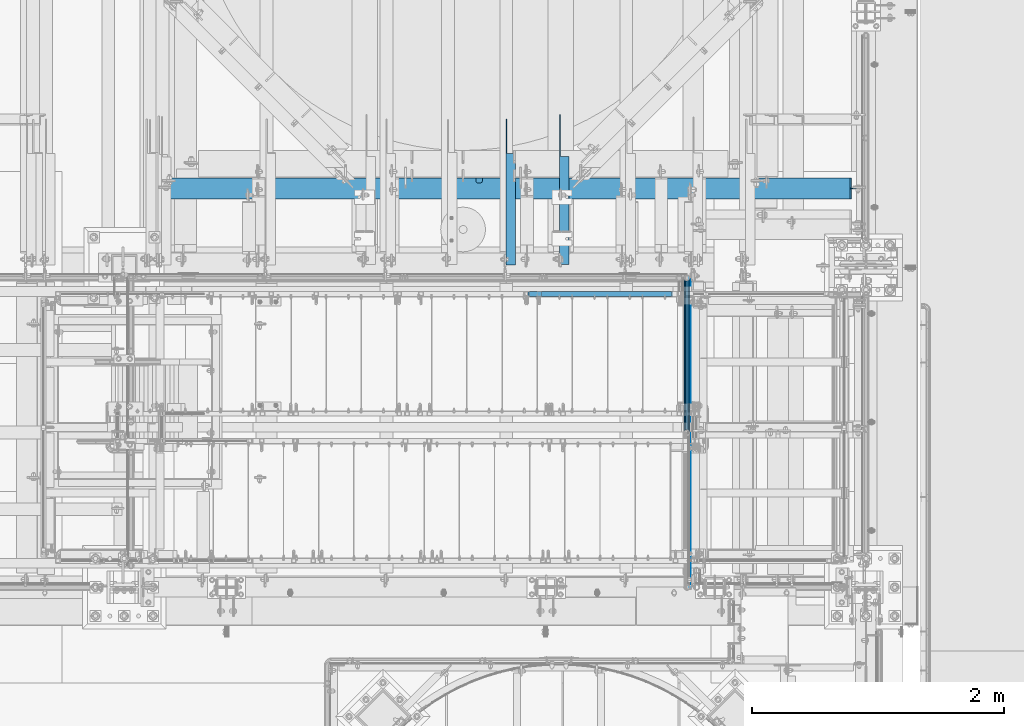
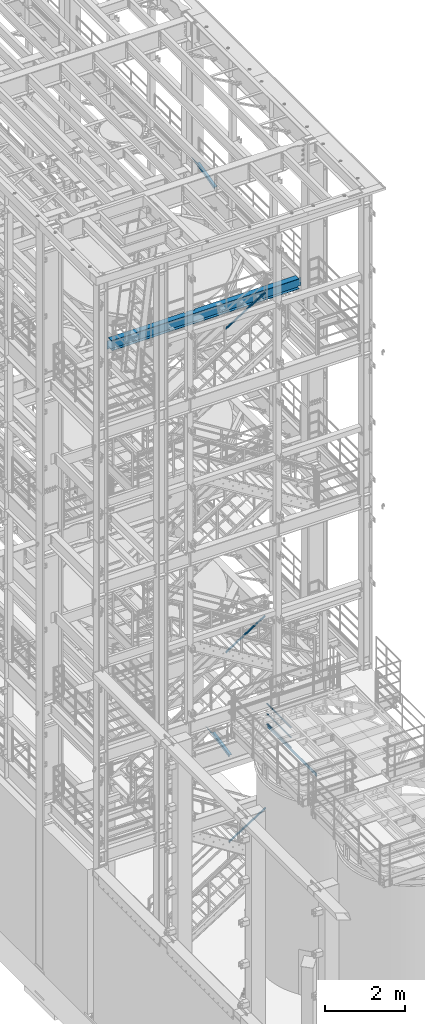
# One storey, part 983 of 1876: 7 beams, 3 members, 7 elements without a shape of their own.
"""IFC2X3 building model written with IfcOpenShell, lengths in millimetres."""

from ifc_helpers import new_model, si_unit, frame, origin_with_axes, place, context, subcontext, project, spatial, faceted_brep, material, type_object, element, aggregate, save


model = new_model("IFC2X3")

# Units and contexts
model_context = context("Model", 3, precision=1e-05, world=origin_with_axes())
body_context = subcontext(model_context, "Body", "Model", "MODEL_VIEW")
ifc_project = project(units=[si_unit("LENGTHUNIT", "METRE", prefix="MILLI"), si_unit("AREAUNIT", "SQUARE_METRE"), si_unit("VOLUMEUNIT", "CUBIC_METRE"), si_unit("MASSUNIT", "GRAM", prefix="KILO"), si_unit("TIMEUNIT", "SECOND"), si_unit("PLANEANGLEUNIT", "RADIAN"), si_unit("SOLIDANGLEUNIT", "STERADIAN"), si_unit("THERMODYNAMICTEMPERATUREUNIT", "DEGREE_CELSIUS"), si_unit("LUMINOUSINTENSITYUNIT", "LUMEN")], contexts=[model_context])

# Site, building, storey
site_placement = place(None, origin_with_axes())
site = spatial("IfcSite", under=ifc_project, at=site_placement, CompositionType="ELEMENT")
building_placement = place(site_placement, origin_with_axes())
building = spatial("IfcBuilding", under=site, at=building_placement, Name="Undefined", CompositionType="ELEMENT")
storey_placement = place(building_placement, origin_with_axes())
storey = spatial("IfcBuildingStorey", under=building, at=storey_placement, Name="Undefined", CompositionType="ELEMENT", Elevation=0.0)

# Assembly, beams
assembly_1_placement = place(storey_placement, origin_with_axes())
assembly_1 = element("IfcElementAssembly", 1, at=assembly_1_placement, inside=storey, Name="RAIL", AssemblyPlace="NOTDEFINED", PredefinedType="RIGID_FRAME")
ifc_material_1 = material()
beam_type_1 = type_object("IfcBeamType", Name="PIPE1-1/2SCH40", PredefinedType="NOTDEFINED")
beam_1_placement = place(assembly_1_placement, frame((6197.59999999999, -4654.55000114548, 5292.725), z_axis=(0.0, 0.0, 1.0), x_axis=(0.0, -1.0, 0.0)))
beam_1 = element("IfcBeam", 2, at=beam_1_placement, type_object=beam_type_1, material=ifc_material_1, Name="RAIL", ObjectType="PIPE1-1/2SCH40", context=body_context, shape_type="Brep", body=[
    faceted_brep([(1207.82780681642, -12.0649999999996, 20.8971929933186), (1207.82780681642, -12.0649999999432, 15.8661214312369), (1207.33437837857, -10.2235000000001, 17.7076214311801), (1204.59499980973, 2.72848410531878e-12, 20.4470000000001), (1204.59499980973, 2.72848410531878e-12, 24.1300000000001), (1207.33437837854, 10.2235000000001, 17.7076214311801), (1207.82780681642, 12.065000000056, 15.8661214311242), (1207.82780681642, 12.0649999999996, 20.8971929933186), (1228.72499980973, 24.1300000000001, 0.0), (1216.65999980973, 20.8971929933186, 12.0649999999996), (1216.65999980973, 20.8971929933186, -12.0649999999996), (1213.47042824754, 17.7076214311801, 10.2235000000001), (1216.20980681636, 20.4470000000001, 0.0), (1213.47042824754, 17.7076214311801, -10.2235000000001), (1207.82780681642, 12.065000000056, -15.8661214311242), (1207.82780681642, 12.0649999999996, -20.8971929933186), (1207.33437837854, 10.2235000000001, -17.7076214311801), (1204.59499980973, 0.0, -20.4470000000001), (1204.59499980973, 0.0, -24.1300000000001), (1207.82780681642, -12.0649999999432, -15.8661214312369), (1207.82780681642, -12.0649999999996, -20.8971929933186), (1207.33437837857, -10.2235000000001, -17.7076214311801), (1228.72499980973, -24.1299999999437, 0.0), (1216.65999980973, -20.8971929933186, -12.0649999999996), (1216.65999980973, -20.8971929933186, 12.0649999999996), (1213.47042824765, -17.7076214311801, -10.2235000000001), (1216.20980681647, -20.4470000000001, 0.0), (1213.47042824765, -17.7076214311801, 10.2235000000001), (12.0650000000064, -20.8971929933177, -12.0649999999987), (20.8971929933249, -12.0650000000005, -20.8971929933177), (0.0, 24.1299999999992, 0.0), (12.0650000000064, 20.8971929933177, -12.0649999999987), (12.0650000000064, 20.8971929933177, 12.0649999999987), (20.8971929933249, 12.0650000000005, 20.8971929933177), (24.1300000000064, 0.0, 24.130000000001), (20.8971929933249, 12.0650000000005, -20.8971929933177), (24.1300000000063, 0.0, -24.130000000001), (24.1300000000063, 0.0, -20.4470000000001), (20.8971929933249, -12.0650000000005, -15.8661214311796), (21.3906214311868, -10.2235000000001, -17.7076214311819), (21.3906214311868, 10.2235000000001, -17.7076214311819), (20.8971929933249, 12.0650000000005, -15.8661214311796), (15.2545715621445, 17.7076214311801, -10.2235000000001), (12.5151929933249, 20.4470000000001, 0.0), (15.2545715621445, 17.7076214311801, 10.2235000000001), (20.8971929933249, 12.0650000000005, 15.8661214311796), (21.3906214311868, 10.2235000000001, 17.7076214311819), (24.1300000000064, 0.0, 20.4470000000001), (21.3906214311868, -10.2235000000001, 17.7076214311819), (20.8971929933249, -12.0650000000005, 15.8661214311796), (20.8971929933249, -12.0650000000005, 20.8971929933177), (12.0650000000064, -20.8971929933177, 12.0649999999987), (0.0, -24.1299999999992, 0.0), (15.2545715621445, -17.7076214311801, 10.2235000000001), (12.5151929933249, -20.4470000000001, 0.0), (15.2545715621445, -17.7076214311801, -10.2235000000001)], [[[0, 1, 2, 3, 4]], [[4, 3, 5, 6, 7]], [[8, 9, 10]], [[7, 6, 11, 12, 13, 14, 15, 10, 9]], [[16, 17, 18, 15, 14]], [[19, 20, 18, 17, 21]], [[22, 23, 24]], [[24, 23, 20, 19, 25, 26, 27, 1, 0]], [[28, 29, 20, 23]], [[30, 31, 32]], [[33, 34, 4, 7]], [[32, 33, 7, 9]], [[30, 32, 9, 8]], [[31, 30, 8, 10]], [[35, 31, 10, 15]], [[36, 35, 15, 18]], [[29, 36, 18, 20]], [[37, 36, 29, 38, 39]], [[40, 41, 35, 36, 37]], [[32, 31, 35, 41, 42, 43, 44, 45, 33]], [[33, 45, 46, 47, 34]], [[34, 47, 48, 49, 50]], [[34, 50, 0, 4]], [[50, 51, 24, 0]], [[51, 52, 22, 24]], [[52, 28, 23, 22]], [[51, 28, 52]], [[50, 49, 53, 54, 55, 38, 29, 28, 51]], [[55, 54, 26, 25]], [[21, 39, 38, 55, 25, 19]], [[37, 39, 21, 17]], [[40, 37, 17, 16]], [[42, 41, 40, 16, 14, 13]], [[43, 42, 13, 12]], [[44, 43, 12, 11]], [[5, 46, 45, 44, 11, 6]], [[47, 46, 5, 3]], [[48, 47, 3, 2]], [[53, 49, 48, 2, 1, 27]], [[54, 53, 27, 26]]]),
])
beam_2_placement = place(assembly_1_placement, frame((6197.60000000216, -5883.27500095527, 5597.525), z_axis=(0.0, 0.0, -1.0), x_axis=(0.0, 1.0, 0.0)))
beam_2 = element("IfcBeam", 3, at=beam_2_placement, type_object=beam_type_1, material=ifc_material_1, Name="RAIL", ObjectType="PIPE1-1/2SCH40", context=body_context, shape_type="Brep", body=[
    faceted_brep([(0.0, 24.1299999999992, 0.0), (12.0650000000064, 20.8971929933177, -12.0649999999987), (12.0650000000064, 20.8971929933177, 12.0649999999987), (12.0650000000064, -20.8971929933177, 12.0649999999987), (12.0650000000064, -20.8971929933177, -12.0649999999987), (0.0, -24.1299999999992, 0.0), (20.8971929933249, -12.0650000000005, 20.8971929933177), (20.8971929933249, -12.0650000000005, 15.8661214311796), (15.2545715621445, -17.7076214311801, 10.2235000000001), (12.5151929933249, -20.4470000000001, 0.0), (15.2545715621445, -17.7076214311801, -10.2235000000001), (20.8971929933249, -12.0650000000005, -15.8661214311796), (20.8971929933249, -12.0650000000005, -20.8971929933177), (24.1300000000063, 0.0, -20.4470000000001), (24.1300000000063, 0.0, -24.130000000001), (21.3906214311868, -10.2235000000001, -17.7076214311819), (21.3906214311868, 10.2235000000001, -17.7076214311819), (20.8971929933249, 12.0650000000005, -15.8661214311796), (20.8971929933249, 12.0650000000005, -20.8971929933177), (15.2545715621445, 17.7076214311801, -10.2235000000001), (12.5151929933249, 20.4470000000001, 0.0), (15.2545715621445, 17.7076214311801, 10.2235000000001), (20.8971929933249, 12.0650000000005, 15.8661214311796), (20.8971929933249, 12.0650000000005, 20.8971929933177), (21.3906214311868, 10.2235000000001, 17.7076214311819), (24.1300000000064, 0.0, 20.4470000000001), (24.1300000000064, 0.0, 24.130000000001), (21.3906214311868, -10.2235000000001, 17.7076214311819), (1228.72499980973, 24.1300000000001, 0.0), (1216.65999980973, 20.8971929933186, -12.0649999999996), (1207.82780681642, 12.0649999999996, -20.8971929933186), (1228.72499980973, -24.1299999999437, 0.0), (1216.65999980973, -20.8971929933186, -12.0649999999996), (1216.65999980973, -20.8971929933186, 12.0649999999996), (1207.82780681642, -12.0649999999996, 20.8971929933186), (1207.82780681642, -12.0649999999996, -20.8971929933186), (1204.59499980973, 0.0, -24.1300000000001), (1207.33437837854, 10.2235000000001, -17.7076214311801), (1204.59499980973, 0.0, -20.4470000000001), (1207.82780681642, 12.065000000056, -15.8661214311242), (1207.82780681642, -12.0649999999432, -15.8661214312369), (1207.33437837857, -10.2235000000001, -17.7076214311801), (1213.47042824765, -17.7076214311801, -10.2235000000001), (1216.20980681647, -20.4470000000001, 0.0), (1213.47042824765, -17.7076214311801, 10.2235000000001), (1207.82780681642, -12.0649999999432, 15.8661214312369), (1207.33437837857, -10.2235000000001, 17.7076214311801), (1204.59499980973, 2.72848410531878e-12, 20.4470000000001), (1204.59499980973, 2.72848410531878e-12, 24.1300000000001), (1207.82780681642, 12.0649999999996, 20.8971929933186), (1216.65999980973, 20.8971929933186, 12.0649999999996), (1207.82780681642, 12.065000000056, 15.8661214311242), (1213.47042824754, 17.7076214311801, 10.2235000000001), (1216.20980681636, 20.4470000000001, 0.0), (1213.47042824754, 17.7076214311801, -10.2235000000001), (1207.33437837854, 10.2235000000001, 17.7076214311801)], [[[0, 1, 2]], [[3, 4, 5]], [[6, 7, 8, 9, 10, 11, 12, 4, 3]], [[13, 14, 12, 11, 15]], [[16, 17, 18, 14, 13]], [[2, 1, 18, 17, 19, 20, 21, 22, 23]], [[23, 22, 24, 25, 26]], [[26, 25, 27, 7, 6]], [[1, 0, 28, 29]], [[18, 1, 29, 30]], [[31, 32, 33]], [[6, 3, 33, 34]], [[3, 5, 31, 33]], [[5, 4, 32, 31]], [[4, 12, 35, 32]], [[12, 14, 36, 35]], [[14, 18, 30, 36]], [[37, 38, 36, 30, 39]], [[40, 35, 36, 38, 41]], [[33, 32, 35, 40, 42, 43, 44, 45, 34]], [[34, 45, 46, 47, 48]], [[26, 6, 34, 48]], [[2, 23, 49, 50]], [[23, 26, 48, 49]], [[0, 2, 50, 28]], [[28, 50, 29]], [[49, 51, 52, 53, 54, 39, 30, 29, 50]], [[48, 47, 55, 51, 49]], [[25, 24, 55, 47]], [[55, 24, 22, 21, 52, 51]], [[21, 20, 53, 52]], [[20, 19, 54, 53]], [[19, 17, 16, 37, 39, 54]], [[16, 13, 38, 37]], [[13, 15, 41, 38]], [[41, 15, 11, 10, 42, 40]], [[10, 9, 43, 42]], [[9, 8, 44, 43]], [[8, 7, 27, 46, 45, 44]], [[27, 25, 47, 46]]]),
])
beam_3_placement = place(assembly_1_placement, frame((6197.60000000216, -5883.27500095527, 5902.325), z_axis=(0.0, 0.0, -1.0), x_axis=(0.0, 1.0, 0.0)))
beam_3 = element("IfcBeam", 4, at=beam_3_placement, type_object=beam_type_1, material=ifc_material_1, Name="RAIL", ObjectType="PIPE1-1/2SCH40", context=body_context, shape_type="Brep", body=[
    faceted_brep([(0.0, 24.1299999999992, 0.0), (12.0650000000064, 20.8971929933177, -12.0649999999987), (12.0650000000064, 20.8971929933177, 12.0649999999987), (12.0650000000064, -20.8971929933177, 12.0649999999987), (12.0650000000064, -20.8971929933177, -12.0649999999987), (0.0, -24.1299999999992, 0.0), (20.8971929933249, -12.0650000000005, 20.8971929933177), (20.8971929933249, -12.0650000000005, 15.8661214311796), (15.2545715621445, -17.7076214311801, 10.2235000000001), (12.5151929933249, -20.4470000000001, 0.0), (15.2545715621445, -17.7076214311801, -10.2235000000001), (20.8971929933249, -12.0650000000005, -15.8661214311796), (20.8971929933249, -12.0650000000005, -20.8971929933177), (24.1300000000063, 0.0, -20.4470000000001), (24.1300000000063, 0.0, -24.130000000001), (21.3906214311868, -10.2235000000001, -17.7076214311819), (21.3906214311868, 10.2235000000001, -17.7076214311819), (20.8971929933249, 12.0650000000005, -15.8661214311796), (20.8971929933249, 12.0650000000005, -20.8971929933177), (15.2545715621445, 17.7076214311801, -10.2235000000001), (12.5151929933249, 20.4470000000001, 0.0), (15.2545715621445, 17.7076214311801, 10.2235000000001), (20.8971929933249, 12.0650000000005, 15.8661214311796), (20.8971929933249, 12.0650000000005, 20.8971929933177), (21.3906214311868, 10.2235000000001, 17.7076214311819), (24.1300000000064, 0.0, 20.4470000000001), (24.1300000000064, 0.0, 24.130000000001), (21.3906214311868, -10.2235000000001, 17.7076214311819), (1228.72499980973, 24.1300000000001, 0.0), (1216.65999980973, 20.8971929933186, -12.0649999999996), (1207.82780681642, 12.0649999999996, -20.8971929933186), (1228.72499980973, -24.1299999999437, 0.0), (1216.65999980973, -20.8971929933186, -12.0649999999996), (1216.65999980973, -20.8971929933186, 12.0649999999996), (1207.82780681642, -12.0649999999996, 20.8971929933186), (1207.82780681642, -12.0649999999996, -20.8971929933186), (1204.59499980973, 0.0, -24.1300000000001), (1207.33437837854, 10.2235000000001, -17.7076214311801), (1204.59499980973, 0.0, -20.4470000000001), (1207.82780681642, 12.065000000056, -15.8661214311242), (1207.82780681642, -12.0649999999432, -15.8661214312369), (1207.33437837857, -10.2235000000001, -17.7076214311801), (1213.47042824765, -17.7076214311801, -10.2235000000001), (1216.20980681647, -20.4470000000001, 0.0), (1213.47042824765, -17.7076214311801, 10.2235000000001), (1207.82780681642, -12.0649999999432, 15.8661214312369), (1207.33437837857, -10.2235000000001, 17.7076214311801), (1204.59499980973, 2.72848410531878e-12, 20.4470000000001), (1204.59499980973, 2.72848410531878e-12, 24.1300000000001), (1207.82780681642, 12.0649999999996, 20.8971929933186), (1216.65999980973, 20.8971929933186, 12.0649999999996), (1207.82780681642, 12.065000000056, 15.8661214311242), (1213.47042824754, 17.7076214311801, 10.2235000000001), (1216.20980681636, 20.4470000000001, 0.0), (1213.47042824754, 17.7076214311801, -10.2235000000001), (1207.33437837854, 10.2235000000001, 17.7076214311801)], [[[0, 1, 2]], [[3, 4, 5]], [[6, 7, 8, 9, 10, 11, 12, 4, 3]], [[13, 14, 12, 11, 15]], [[16, 17, 18, 14, 13]], [[2, 1, 18, 17, 19, 20, 21, 22, 23]], [[23, 22, 24, 25, 26]], [[26, 25, 27, 7, 6]], [[1, 0, 28, 29]], [[18, 1, 29, 30]], [[31, 32, 33]], [[6, 3, 33, 34]], [[3, 5, 31, 33]], [[5, 4, 32, 31]], [[4, 12, 35, 32]], [[12, 14, 36, 35]], [[14, 18, 30, 36]], [[37, 38, 36, 30, 39]], [[40, 35, 36, 38, 41]], [[33, 32, 35, 40, 42, 43, 44, 45, 34]], [[34, 45, 46, 47, 48]], [[26, 6, 34, 48]], [[2, 23, 49, 50]], [[23, 26, 48, 49]], [[0, 2, 50, 28]], [[28, 50, 29]], [[49, 51, 52, 53, 54, 39, 30, 29, 50]], [[48, 47, 55, 51, 49]], [[25, 24, 55, 47]], [[55, 24, 22, 21, 52, 51]], [[21, 20, 53, 52]], [[20, 19, 54, 53]], [[19, 17, 16, 37, 39, 54]], [[16, 13, 38, 37]], [[13, 15, 41, 38]], [[41, 15, 11, 10, 42, 40]], [[10, 9, 43, 42]], [[9, 8, 44, 43]], [[8, 7, 27, 46, 45, 44]], [[27, 25, 47, 46]]]),
])
ifc_material_2 = material(Name="STEEL/A36")
beam_type_2 = type_object("IfcBeamType", PredefinedType="NOTDEFINED")
beam_4_placement = place(assembly_1_placement, frame((6224.58750001983, -7112.00000077382, 5197.475), z_axis=(0.0, 0.0, 1.0), x_axis=(0.0, 1.0, 0.0)))
beam_4 = element("IfcBeam", 5, at=beam_4_placement, type_object=beam_type_2, material=ifc_material_2, Name="PLATE", context=body_context, shape_type="Brep", body=[
    faceted_brep([(0.0, 3.17500000000018, -50.8000000000002), (0.0, 3.17500000000018, 50.8000000000002), (2457.45000039182, 3.17500000000018, 50.8000000000002), (2457.45000039182, 3.17500000000018, -50.8000000000002), (0.0, -3.17500000000018, 50.8000000000002), (2457.45000039182, -3.17500000000018, 50.8000000000002), (0.0, -3.17500000000018, -50.8000000000002), (2457.45000039182, -3.17500000000018, -50.8000000000002)], [[[0, 1, 2, 3]], [[1, 4, 5, 2]], [[4, 6, 7, 5]], [[6, 0, 3, 7]], [[5, 7, 3, 2]], [[6, 4, 1, 0]]]),
])
aggregate(assembly_1, [beam_1, beam_2, beam_4, beam_3])

# Assembly, beam
assembly_2_placement = place(storey_placement, origin_with_axes())
assembly_2 = element("IfcElementAssembly", 6, at=assembly_2_placement, inside=storey, AssemblyPlace="NOTDEFINED", PredefinedType="RIGID_FRAME")
beam_type_3 = type_object("IfcBeamType", Name="L3X3X3/8", PredefinedType="NOTDEFINED")
beam_5_placement = place(assembly_2_placement, frame((4797.42500019074, -4562.78281844778, 21997.5317219592), z_axis=(1.0, 0.0, 0.0), x_axis=(0.0, 0.97029600569138, 0.241920774923019)))
beam_5 = element("IfcBeam", 7, at=beam_5_placement, type_object=beam_type_3, material=ifc_material_2, ObjectType="L3X3X3/8", context=body_context, shape_type="Brep", body=[
    faceted_brep([(20.4512332895073, 38.1000000000495, -38.0999999999999), (20.4512332895073, 38.1000000000495, 38.0999999999999), (892.440924395522, 38.0999999997366, 38.0999999999999), (892.440924395522, 38.0999999997366, -38.0999999999999), (20.4512332895037, 28.5750000000371, 38.0999999999999), (930.643800759319, 28.5749999997061, 38.0999999999999), (20.4512332895037, 28.5750000000371, -28.575), (930.643800759319, 28.5749999997061, -28.575), (20.4512332894728, -38.1000000000604, -28.575), (1198.0639353059, -38.1000000004824, -28.575), (20.4512332894728, -38.1000000000604, -38.0999999999999), (1198.0639353059, -38.1000000004824, -38.0999999999999)], [[[0, 1, 2, 3]], [[1, 4, 5, 2]], [[4, 6, 7, 5]], [[6, 8, 9, 7]], [[8, 10, 11, 9]], [[10, 0, 3, 11]], [[5, 7, 9, 11, 3, 2]], [[10, 8, 6, 4, 1, 0]]]),
])
aggregate(assembly_2, [beam_5])

assembly_3_placement = place(storey_placement, origin_with_axes())
assembly_3 = element("IfcElementAssembly", 8, at=assembly_3_placement, inside=storey, AssemblyPlace="NOTDEFINED", PredefinedType="RIGID_FRAME")
beam_6_placement = place(assembly_3_placement, frame((5222.08125, -4564.3470414959, 4572.77651984672), z_axis=(1.0, 0.0, 0.0), x_axis=(0.0, 0.979618903835332, 0.200865136966229)))
beam_6 = element("IfcBeam", 9, at=beam_6_placement, type_object=beam_type_3, material=ifc_material_2, ObjectType="L3X3X3/8", context=body_context, shape_type="Brep", body=[
    faceted_brep([(23.4976613090944, 38.0999999999913, -38.0999999999999), (23.4976613090944, 38.0999999999913, 38.0999999999999), (853.557777655543, 38.0999999998658, 38.0999999999999), (853.557777655543, 38.0999999998658, -38.0999999999999), (23.4976613090939, 28.5749999999935, 38.0999999999999), (900.01118515057, 28.5749999998607, 38.0999999999999), (23.4976613090939, 28.5749999999935, -28.5749999999998), (900.01118515057, 28.5749999998607, -28.5749999999998), (23.4976613090939, -38.0999999999976, -28.5749999999998), (1225.18503761576, -38.1000000001786, -28.5749999999998), (23.4976613090939, -38.0999999999976, -38.0999999999999), (1225.18503761576, -38.1000000001786, -38.0999999999999)], [[[0, 1, 2, 3]], [[1, 4, 5, 2]], [[4, 6, 7, 5]], [[6, 8, 9, 7]], [[8, 10, 11, 9]], [[10, 0, 3, 11]], [[5, 7, 9, 11, 3, 2]], [[10, 8, 6, 4, 1, 0]]]),
])
aggregate(assembly_3, [beam_6])

# Assembly, member
assembly_4_placement = place(storey_placement, origin_with_axes())
assembly_4 = element("IfcElementAssembly", 10, at=assembly_4_placement, inside=storey, Name="RAIL", AssemblyPlace="NOTDEFINED", PredefinedType="RIGID_FRAME")
ifc_material_3 = material()
member_type = type_object("IfcMemberType", Name="HSS1-1/2X1-1/2X1/8", PredefinedType="NOTDEFINED")
member_1_placement = place(assembly_4_placement, frame((4927.59999403871, -4781.55000114554, 7952.79772180429), z_axis=(-0.536875491934336, 0.0, 0.843661487896813), x_axis=(0.843661487896813, 0.0, 0.536875491934336)))
member_1 = element("IfcMember", 11, at=member_1_placement, type_object=member_type, material=ifc_material_3, Name="RAIL", ObjectType="HSS1-1/2X1-1/2X1/8", context=body_context, shape_type="Brep", body=[
    faceted_brep([(12.4778733370622, 15.8749992829999, -15.8749992829939), (12.4778733370622, -15.8749992829999, -15.8749992829939), (1362.551306878, -15.8749992829999, -15.8749992825196), (1362.551306878, 15.8749992829999, -15.8749992825196), (32.6824178653787, -15.8749992829999, 15.8749992830085), (1371.79692826457, -15.8749992829999, 15.8749992834796), (32.6824178653787, 15.8749992829999, 15.8749992830085), (1371.79692826457, 15.8749992829999, 15.8749992834796), (10.4574188235219, 19.0499992349996, -19.0499992349946), (34.7028723789208, 19.0499992349996, 19.0499992350083), (1372.721490431, 19.0499992349996, 19.049999235478), (1361.62674471157, 19.0499992349996, -19.0499992345181), (34.7028723789208, -19.0499992349996, 19.0499992350083), (1372.721490431, -19.0499992349996, 19.049999235478), (10.4574188235219, -19.0499992349996, -19.0499992349946), (1361.62674471157, -19.0499992349996, -19.0499992345181)], [[[0, 1, 2, 3]], [[1, 4, 5, 2]], [[4, 6, 7, 5]], [[6, 0, 3, 7]], [[8, 9, 10, 11]], [[9, 12, 13, 10]], [[12, 14, 15, 13]], [[14, 8, 11, 15]], [[13, 15, 11, 10], [5, 7, 3, 2]], [[14, 12, 9, 8], [6, 4, 1, 0]]]),
])
aggregate(assembly_4, [member_1])

assembly_5_placement = place(storey_placement, origin_with_axes())
assembly_5 = element("IfcElementAssembly", 12, at=assembly_5_placement, inside=storey, Name="RAIL", AssemblyPlace="NOTDEFINED", PredefinedType="RIGID_FRAME")
member_2_placement = place(assembly_5_placement, frame((5025.23125001361, -4781.55000114554, 2158.38322611075), z_axis=(-0.53569741975471, 0.0, 0.844410015613355), x_axis=(0.844410015326383, 0.0, 0.535697420207059)))
member_2 = element("IfcMember", 13, at=member_2_placement, type_object=member_type, material=ifc_material_3, Name="RAIL", ObjectType="HSS1-1/2X1-1/2X1/8", context=body_context, shape_type="Brep", body=[
    faceted_brep([(12.4889602027924, 15.8749992829999, -15.8749992829981), (12.4889602027924, -15.8749992829999, -15.8749992829981), (1263.45653096949, -15.8749992829999, -15.8749992826649), (1263.45653096949, 15.8749992829999, -15.8749992826649), (32.6312986338025, -15.8749992829999, 15.8749992830109), (1272.67812060826, -15.8749992829999, 15.8749992833416), (32.6312986338025, 15.8749992829999, 15.8749992830109), (1272.67812060826, 15.8749992829999, 15.8749992833416), (10.4747262991696, 19.0499992349996, -19.0499992349991), (34.6455325374254, 19.0499992349996, 19.049999235012), (1273.60027959985, 19.0499992349996, 19.0499992353423), (1262.5343719779, 19.0499992349996, -19.0499992346656), (34.6455325374254, -19.0499992349996, 19.049999235012), (1273.60027959985, -19.0499992349996, 19.0499992353423), (10.4747262991696, -19.0499992349996, -19.0499992349991), (1262.5343719779, -19.0499992349996, -19.0499992346656)], [[[0, 1, 2, 3]], [[1, 4, 5, 2]], [[4, 6, 7, 5]], [[6, 0, 3, 7]], [[8, 9, 10, 11]], [[9, 12, 13, 10]], [[12, 14, 15, 13]], [[14, 8, 11, 15]], [[13, 15, 11, 10], [5, 7, 3, 2]], [[14, 12, 9, 8], [6, 4, 1, 0]]]),
])
aggregate(assembly_5, [member_2])

assembly_6_placement = place(storey_placement, origin_with_axes())
assembly_6 = element("IfcElementAssembly", 14, at=assembly_6_placement, inside=storey, Name="RAIL", AssemblyPlace="NOTDEFINED", PredefinedType="RIGID_FRAME")
member_3_placement = place(assembly_6_placement, frame((4918.07499723937, -4781.55000114554, 17796.4107168866), z_axis=(-0.526627379729772, 0.0, 0.850096231563789), x_axis=(0.850096231563789, 0.0, 0.526627379729772)))
member_3 = element("IfcMember", 15, at=member_3_placement, type_object=member_type, material=ifc_material_3, Name="RAIL", ObjectType="HSS1-1/2X1-1/2X1/8", context=body_context, shape_type="Brep", body=[
    faceted_brep([(12.574799847971, 15.8749992829999, -15.8749992829671), (12.574799847971, -15.8749992829999, -15.8749992829671), (1363.03122273674, -15.8749992829999, -15.8749992810117), (1363.03122273674, 15.8749992829999, -15.8749992810117), (32.243653714735, -15.8749992829999, 15.8749992830344), (1372.06881669865, -15.8749992829999, 15.8749992849771), (32.243653714735, 15.8749992829999, 15.8749992830344), (1372.06881669865, 15.8749992829999, 15.8749992849771), (10.6079144021951, 19.0499992349996, -19.0499992349669), (34.210539160511, 19.0499992349996, 19.0499992350342), (1372.972576122, 19.0499992349996, 19.0499992369769), (1362.12746331339, 19.0499992349996, -19.0499992330097), (34.210539160511, -19.0499992349996, 19.0499992350342), (1372.972576122, -19.0499992349996, 19.0499992369769), (10.6079144021951, -19.0499992349996, -19.0499992349669), (1362.12746331339, -19.0499992349996, -19.0499992330097)], [[[0, 1, 2, 3]], [[1, 4, 5, 2]], [[4, 6, 7, 5]], [[6, 0, 3, 7]], [[8, 9, 10, 11]], [[9, 12, 13, 10]], [[12, 14, 15, 13]], [[14, 8, 11, 15]], [[13, 15, 11, 10], [5, 7, 3, 2]], [[14, 12, 9, 8], [6, 4, 1, 0]]]),
])
aggregate(assembly_6, [member_3])

# Assembly, beam
assembly_7_placement = place(storey_placement, origin_with_axes())
assembly_7 = element("IfcElementAssembly", 16, at=assembly_7_placement, inside=storey, Name="BEAM", AssemblyPlace="NOTDEFINED", PredefinedType="RIGID_FRAME")
ifc_material_4 = material(Name="STEEL/A992")
beam_type_4 = type_object("IfcBeamType", Name="W12X30", PredefinedType="NOTDEFINED")
beam_7_placement = place(assembly_7_placement, frame((2000.24988645128, -3943.35, 17826.0375), z_axis=(0.0, 0.0, 1.0), x_axis=(1.0, 0.0, 0.0)))
beam_7 = element("IfcBeam", 17, at=beam_7_placement, type_object=beam_type_4, material=ifc_material_4, Name="BEAM", ObjectType="W12X30", context=body_context, shape_type="Brep", body=[
    faceted_brep([(2520.9486397771, 57.1500013351447, 157.162499999999), (2520.9486397771, 57.1500013351447, 146.049999999999), (2520.9486397771, 82.5500000000002, 146.049999999999), (2520.9486397771, 82.5500000000002, 157.162499999999), (2521.91536969969, 52.2899218170992, 157.162499999999), (2521.91536969969, 52.2899218170992, 146.049999999999), (2524.66838360016, 48.1697453489455, 157.162499999999), (2524.66838360016, 48.1697453489455, 146.049999999999), (2528.78856006832, 45.4167314484675, 157.162499999999), (2528.78856006832, 45.4167314484675, 146.049999999999), (2533.64863958636, 44.4500015258795, 157.162499999999), (2533.64863958636, 44.4500015258795, 146.049999999999), (2559.0486353902, 44.4500015258795, 157.162499999999), (2559.0486353902, 44.4500015258795, 146.049999999999), (2563.90871490824, 45.4167314484675, 157.162499999999), (2563.90871490824, 45.4167314484675, 146.049999999999), (2568.02889137639, 48.1697453489455, 157.162499999999), (2568.02889137639, 48.1697453489455, 146.049999999999), (2570.78190527687, 52.2899218170992, 157.162499999999), (2570.78190527687, 52.2899218170992, 146.049999999999), (2571.74863519946, 57.1500013351447, 157.162499999999), (2571.74863519946, 57.1500013351447, 146.049999999999), (2571.74863519946, 82.5500000000002, 157.162499999999), (2571.74863519946, 82.5500000000002, 146.049999999999), (95.25, -82.5500000000002, 157.1625), (95.25, -82.5500000000002, 146.05), (5491.95636354872, -82.5500000000002, 146.049999999999), (5491.95636354872, -82.5500000000002, 157.162499999999), (5599.90636354872, 3.17500000000018, 119.062500000004), (5599.90636354872, -3.17500000000018, 119.062500000004), (5599.90636354872, -3.17500000000018, -125.412499999995), (5599.90636354872, 3.17500000000018, -125.412499999995), (5504.65636335798, 3.17500000000018, 119.062500000004), (5504.65636335798, -3.17500000000018, 119.062500000004), (5499.79628383994, 3.17500000000018, 120.029229922591), (5499.79628383994, -3.17500000000018, 120.029229922591), (5495.67610737178, 3.17500000000018, 122.782243823069), (5495.67610737178, -3.17500000000018, 122.782243823069), (5492.9230934713, 3.17500000000018, 126.902420291222), (5492.9230934713, -3.17500000000018, 126.902420291222), (5491.95636354872, 3.17500000000018, 131.762499809269), (5491.95636354872, -3.17500000000018, 131.762499809269), (95.25, -3.17500000000018, 144.462499809266), (95.25, 3.17500000000018, 144.462499809266), (94.2832700774125, 3.17500000000018, 139.60242029122), (94.2832700774125, -3.17500000000018, 139.60242029122), (91.530256176934, 3.17500000000018, 135.482243823067), (91.530256176934, -3.17500000000018, 135.482243823067), (87.4100797087804, 3.17500000000018, 132.729229922588), (87.4100797087804, -3.17500000000018, 132.729229922588), (82.5500001907349, 3.17500000000018, 131.762500000001), (82.5500001907349, -3.17500000000018, 131.762500000001), (15.875, 3.17500000000018, 131.762500000001), (15.875, -3.17500000000018, 131.762500000001), (15.875, 3.17500000000018, -125.412500000006), (15.875, -3.17500000000018, -125.412500000006), (98.4250001907351, 3.17500000000018, -125.412500000006), (98.4250001907351, -3.17500000000018, -125.412500000006), (103.285079708781, 3.17500000000018, -126.379229922593), (103.285079708781, -3.17500000000018, -126.379229922593), (107.405256176934, 3.17500000000018, -129.132243823071), (107.405256176934, -3.17500000000018, -129.132243823071), (110.158270077412, 3.17500000000018, -133.252420291225), (110.158270077412, -3.17500000000018, -133.252420291225), (111.125, 3.17500000000018, -138.112499809271), (111.125, -3.17500000000018, -138.112499809271), (5491.95636354872, -3.17500000000018, 146.049999999999), (95.2499999999982, -3.17500000000018, 146.049999999999), (111.124999999998, -3.17500000000018, -146.049999999999), (5504.65636354872, -3.17500000000018, -146.049999999999), (5504.65636354872, -3.17500000000018, -138.11249980926), (5505.6230934713, -3.17500000000018, -133.252420291214), (5508.37610737178, -3.17500000000018, -129.13224382306), (5512.49628383994, -3.17500000000018, -126.379229922582), (5517.35636335798, -3.17500000000018, -125.412499999995), (111.125, 82.5500000000002, -157.1625), (111.125, 82.5500000000002, -146.05), (5504.65636354872, 82.5500000000002, -146.049999999999), (5504.65636354872, 82.5500000000002, -157.162499999999), (111.125, -82.5500000000002, -157.1625), (5504.65636354872, -82.5500000000002, -157.162499999999), (111.125, -82.5500000000002, -146.05), (5504.65636354872, -82.5500000000002, -146.049999999999), (111.124999999998, 3.17500000000018, -146.049999999999), (5504.65636354872, 3.17500000000018, -146.049999999999), (5504.65636354872, 3.17500000000018, -138.11249980926), (5505.6230934713, 3.17500000000018, -133.252420291214), (5508.37610737178, 3.17500000000018, -129.13224382306), (5512.49628383994, 3.17500000000018, -126.379229922582), (5517.35636335798, 3.17500000000018, -125.412499999995), (95.2499999999982, 3.17500000000018, 146.049999999999), (5491.95636354872, 3.17500000000018, 146.049999999999), (5491.95636354872, 82.5500000000002, 146.049999999999), (5491.95636354872, 82.5500000000002, 157.162499999999), (95.25, 82.5500000000002, 157.1625), (95.25, 82.5500000000002, 146.05), (2266.9486397771, 82.5500000000002, 157.162499999999), (2266.9486397771, 82.5500000000002, 146.049999999999), (2266.9486397771, 57.1500013351447, 157.162499999999), (2266.9486397771, 57.1500013351447, 146.049999999999), (2267.91536969969, 52.2899218170992, 157.162499999999), (2267.91536969969, 52.2899218170992, 146.049999999999), (2270.66838360016, 48.1697453489455, 157.162499999999), (2270.66838360016, 48.1697453489455, 146.049999999999), (2274.78856006832, 45.4167314484675, 157.162499999999), (2274.78856006832, 45.4167314484675, 146.049999999999), (2279.64863958636, 44.4500015258795, 157.162499999999), (2279.64863958636, 44.4500015258795, 146.049999999999), (2305.0486353902, 44.4500015258795, 157.162499999999), (2305.0486353902, 44.4500015258795, 146.049999999999), (2309.90871490824, 45.4167314484675, 157.162499999999), (2309.90871490824, 45.4167314484675, 146.049999999999), (2314.02889137639, 48.1697453489455, 157.162499999999), (2314.02889137639, 48.1697453489455, 146.049999999999), (2316.78190527687, 52.2899218170992, 157.162499999999), (2316.78190527687, 52.2899218170992, 146.049999999999), (2317.74863519946, 57.1500013351447, 157.162499999999), (2317.74863519946, 57.1500013351447, 146.049999999999), (2317.74863519946, 82.5500000000002, 157.162499999999), (2317.74863519946, 82.5500000000002, 146.049999999999)], [[[0, 1, 2, 3]], [[4, 5, 1, 0]], [[6, 7, 5, 4]], [[8, 9, 7, 6]], [[10, 11, 9, 8]], [[12, 13, 11, 10]], [[14, 15, 13, 12]], [[16, 17, 15, 14]], [[18, 19, 17, 16]], [[20, 21, 19, 18]], [[22, 23, 21, 20]], [[24, 25, 26, 27]], [[28, 29, 30, 31]], [[29, 28, 32, 33]], [[33, 32, 34, 35]], [[35, 34, 36, 37]], [[37, 36, 38, 39]], [[39, 38, 40, 41]], [[42, 43, 44, 45]], [[45, 44, 46, 47]], [[47, 46, 48, 49]], [[49, 48, 50, 51]], [[51, 50, 52, 53]], [[53, 52, 54, 55]], [[55, 54, 56, 57]], [[57, 56, 58, 59]], [[59, 58, 60, 61]], [[61, 60, 62, 63]], [[63, 62, 64, 65]], [[29, 33, 35, 37, 39, 41, 66, 67, 42, 45, 47, 49, 51, 53, 55, 57, 59, 61, 63, 65, 68, 69, 70, 71, 72, 73, 74, 30]], [[75, 76, 77, 78]], [[79, 75, 78, 80]], [[81, 79, 80, 82]], [[68, 81, 82, 69]], [[65, 64, 83, 76, 75, 79, 81, 68]], [[76, 83, 84, 77]], [[69, 82, 80, 78, 77, 84, 85, 70]], [[70, 85, 86, 71]], [[71, 86, 87, 72]], [[72, 87, 88, 73]], [[73, 88, 89, 74]], [[30, 74, 89, 31]], [[88, 87, 86, 85, 84, 83, 64, 62, 60, 58, 56, 54, 52, 50, 48, 46, 44, 43, 90, 91, 40, 38, 36, 34, 32, 28, 31, 89]], [[27, 26, 66, 41, 40, 91, 92, 93]], [[25, 67, 66, 26]], [[24, 94, 95, 90, 43, 42, 67, 25]], [[95, 94, 96, 97]], [[98, 99, 97, 96]], [[100, 101, 99, 98]], [[102, 103, 101, 100]], [[104, 105, 103, 102]], [[106, 107, 105, 104]], [[108, 109, 107, 106]], [[110, 111, 109, 108]], [[112, 113, 111, 110]], [[114, 115, 113, 112]], [[116, 117, 115, 114]], [[118, 119, 117, 116]], [[119, 118, 3, 2]], [[92, 91, 90, 95, 97, 99, 101, 103, 105, 107, 109, 111, 113, 115, 117, 119, 2, 1, 5, 7, 9, 11, 13, 15, 17, 19, 21, 23]], [[93, 92, 23, 22]], [[16, 14, 12, 10, 8, 6, 4, 0, 3, 118, 116, 114, 112, 110, 108, 106, 104, 102, 100, 98, 96, 94, 24, 27, 93, 22, 20, 18]]]),
])
aggregate(assembly_7, [beam_7])

save(model, "model.ifc")
